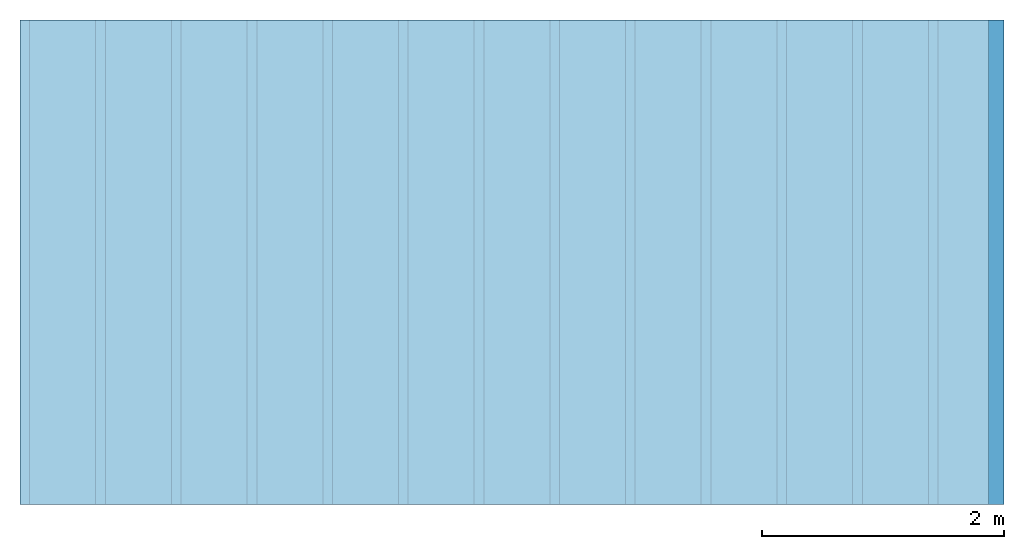
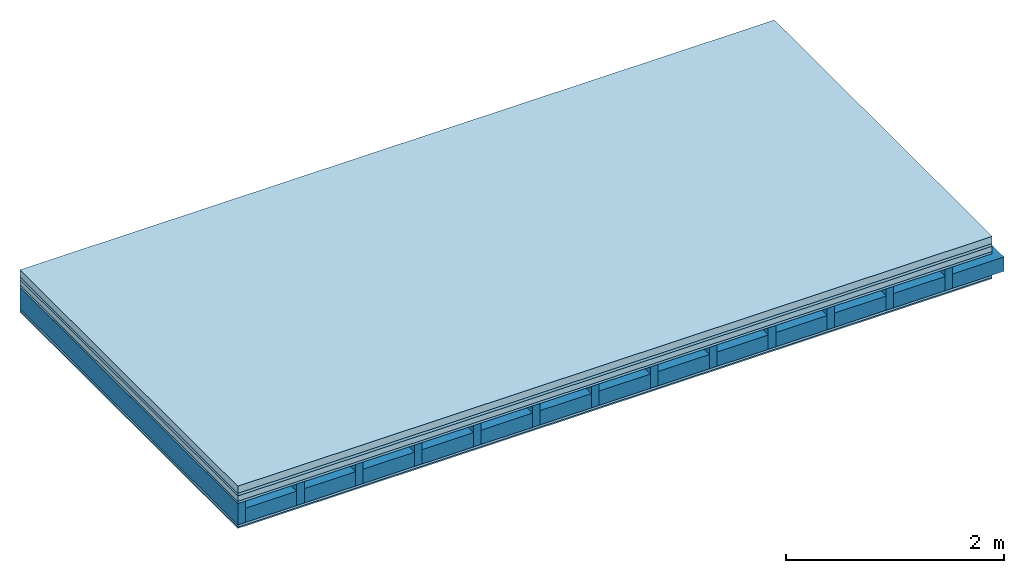
# One storey: 6 plates, 2 members, 1 element without a shape of its own.
"""IFC4 building model written with IfcOpenShell, lengths in metres."""

from ifc_helpers import new_model, si_unit, derived_unit, direction, frame, frame_2d, origin, origin_with_axes, place, context, project, spatial, rectangle, extrude, material, layer, layer_set, type_object, element, aggregate, save


model = new_model("IFC4")

# Units and contexts
plan_context = context("Plan", 3, precision=1e-05, world=origin(), true_north=direction((0.0, 1.0)))
model_context = context("Model", 3, precision=1e-05, world=origin(), true_north=direction((0.0, 1.0)))
ifc_project = project(units=[si_unit("LENGTHUNIT", "METRE"), derived_unit("SOUNDPRESSUREUNIT", [(si_unit("PRESSUREUNIT", "PASCAL", prefix="MICRO"), 0)]), si_unit("ENERGYUNIT", "JOULE", prefix="MEGA"), si_unit("MASSUNIT", "GRAM", prefix="KILO"), derived_unit("THERMALTRANSMITTANCEUNIT", [(si_unit("POWERUNIT", "WATT"), 1), (si_unit("AREAUNIT", "SQUARE_METRE"), -1), (si_unit("THERMODYNAMICTEMPERATUREUNIT", "KELVIN"), -1)]), derived_unit("AREADENSITYUNIT", [(si_unit("MASSUNIT", "GRAM", prefix="KILO"), 1), (si_unit("AREAUNIT", "SQUARE_METRE"), -1)]), derived_unit("USERDEFINED", [(si_unit("ENERGYUNIT", "JOULE", prefix="MEGA"), 1), (si_unit("AREAUNIT", "SQUARE_METRE"), -1)])], contexts=[plan_context, model_context])

# Site, building, storey
site = spatial("IfcSite", under=ifc_project)
building_placement = place(None, origin())
building = spatial("IfcBuilding", under=site, at=building_placement)
storey_placement = place(building_placement, origin())
storey = spatial("IfcBuildingStorey", under=building, at=storey_placement)

# Slab, members, plates
ifc_material_1 = material(Name="Cement screed", Category="04.006")
ifc_layer_1 = layer(ifc_material_1, 0.08, Name="On-material")
ifc_material_2 = material()
ifc_layer_2 = layer(ifc_material_2, 0.03, Name="Impact sound insulation")
ifc_material_3 = material(Name="Cement panels, glued on sub-floor", Category="02.007")
ifc_layer_3 = layer(ifc_material_3, 0.06, Name="on Supporting structure")
ifc_material_4 = material(Category="07.001")
ifc_layer_4 = layer(ifc_material_4, 0.025, Name="Sub-floor")
ifc_material_5 = material(Name="Rigid, of the art")
ifc_layer_5 = layer(ifc_material_5, 0.0, Name="Bond")
ifc_layer_6 = layer(None, 0.24, Name="Supporting structure")
ifc_layer_7 = layer(ifc_material_5, 0.0, Name="Bond")
ifc_layer_8 = layer(ifc_material_4, 0.025, Name="Lower layer 1")
ifc_material_6 = material(Category="03.007")
ifc_layer_9 = layer(ifc_material_6, 0.015, Name="Lower 2nd layer")
ifc_layer_set = layer_set([ifc_layer_1, ifc_layer_2, ifc_layer_3, ifc_layer_4, ifc_layer_5, ifc_layer_6, ifc_layer_7, ifc_layer_8, ifc_layer_9])
slab_type = type_object("IfcSlabType", Name="A0432", PredefinedType="NOTDEFINED", material=ifc_layer_set)
slab_placement = place(None, frame((0.0, 0.0, 0.0), z_axis=(0.0, 0.0, -1.0), x_axis=(1.0, 0.0, 0.0)))
slab = element("IfcSlab", 1, at=slab_placement, inside=storey, type_object=slab_type, material=ifc_layer_set, Name="Slab #1")
ifc_material_7 = material()
member_1_placement = place(slab_placement, origin())
member_1 = element("IfcMember", 2, at=member_1_placement, material=ifc_material_7, Name="Supporting structure", context=plan_context, shape_type="SweptSolid", body=[
    extrude(rectangle(XDim=0.08, YDim=0.24, at=frame_2d((0.04, 0.12), x_axis=(1.0, 0.0))), frame((0.0, 4.0, 0.195), z_axis=(0.0, -1.0, 0.0), x_axis=(1.0, 0.0, 0.0)), (0.0, 0.0, 1.0), 4.0),
    extrude(rectangle(XDim=0.08, YDim=0.24, at=frame_2d((0.04, 0.12), x_axis=(1.0, 0.0))), frame((0.625, 4.0, 0.195), z_axis=(0.0, -1.0, 0.0), x_axis=(1.0, 0.0, 0.0)), (0.0, 0.0, 1.0), 4.0),
    extrude(rectangle(XDim=0.08, YDim=0.24, at=frame_2d((0.04, 0.12), x_axis=(1.0, 0.0))), frame((1.25, 4.0, 0.195), z_axis=(0.0, -1.0, 0.0), x_axis=(1.0, 0.0, 0.0)), (0.0, 0.0, 1.0), 4.0),
    extrude(rectangle(XDim=0.08, YDim=0.24, at=frame_2d((0.04, 0.12), x_axis=(1.0, 0.0))), frame((1.875, 4.0, 0.195), z_axis=(0.0, -1.0, 0.0), x_axis=(1.0, 0.0, 0.0)), (0.0, 0.0, 1.0), 4.0),
    extrude(rectangle(XDim=0.08, YDim=0.24, at=frame_2d((0.04, 0.12), x_axis=(1.0, 0.0))), frame((2.5, 4.0, 0.195), z_axis=(0.0, -1.0, 0.0), x_axis=(1.0, 0.0, 0.0)), (0.0, 0.0, 1.0), 4.0),
    extrude(rectangle(XDim=0.08, YDim=0.24, at=frame_2d((0.04, 0.12), x_axis=(1.0, 0.0))), frame((3.125, 4.0, 0.195), z_axis=(0.0, -1.0, 0.0), x_axis=(1.0, 0.0, 0.0)), (0.0, 0.0, 1.0), 4.0),
    extrude(rectangle(XDim=0.08, YDim=0.24, at=frame_2d((0.04, 0.12), x_axis=(1.0, 0.0))), frame((3.75, 4.0, 0.195), z_axis=(0.0, -1.0, 0.0), x_axis=(1.0, 0.0, 0.0)), (0.0, 0.0, 1.0), 4.0),
    extrude(rectangle(XDim=0.08, YDim=0.24, at=frame_2d((0.04, 0.12), x_axis=(1.0, 0.0))), frame((4.375, 4.0, 0.195), z_axis=(0.0, -1.0, 0.0), x_axis=(1.0, 0.0, 0.0)), (0.0, 0.0, 1.0), 4.0),
    extrude(rectangle(XDim=0.08, YDim=0.24, at=frame_2d((0.04, 0.12), x_axis=(1.0, 0.0))), frame((5.0, 4.0, 0.195), z_axis=(0.0, -1.0, 0.0), x_axis=(1.0, 0.0, 0.0)), (0.0, 0.0, 1.0), 4.0),
    extrude(rectangle(XDim=0.08, YDim=0.24, at=frame_2d((0.04, 0.12), x_axis=(1.0, 0.0))), frame((5.625, 4.0, 0.195), z_axis=(0.0, -1.0, 0.0), x_axis=(1.0, 0.0, 0.0)), (0.0, 0.0, 1.0), 4.0),
    extrude(rectangle(XDim=0.08, YDim=0.24, at=frame_2d((0.04, 0.12), x_axis=(1.0, 0.0))), frame((6.25, 4.0, 0.195), z_axis=(0.0, -1.0, 0.0), x_axis=(1.0, 0.0, 0.0)), (0.0, 0.0, 1.0), 4.0),
    extrude(rectangle(XDim=0.08, YDim=0.24, at=frame_2d((0.04, 0.12), x_axis=(1.0, 0.0))), frame((6.875, 4.0, 0.195), z_axis=(0.0, -1.0, 0.0), x_axis=(1.0, 0.0, 0.0)), (0.0, 0.0, 1.0), 4.0),
    extrude(rectangle(XDim=0.08, YDim=0.24, at=frame_2d((0.04, 0.12), x_axis=(1.0, 0.0))), frame((7.5, 4.0, 0.195), z_axis=(0.0, -1.0, 0.0), x_axis=(1.0, 0.0, 0.0)), (0.0, 0.0, 1.0), 4.0),
])
ifc_material_8 = material()
member_2_placement = place(slab_placement, origin())
member_2 = element("IfcMember", 3, at=member_2_placement, material=ifc_material_8, Name="Cavity", context=plan_context, shape_type="SweptSolid", body=[
    extrude(rectangle(XDim=0.545, YDim=0.16, at=frame_2d((0.2725, 0.08), x_axis=(1.0, 0.0))), frame((0.08, 4.0, 0.275), z_axis=(0.0, -1.0, 0.0), x_axis=(1.0, 0.0, 0.0)), (0.0, 0.0, 1.0), 4.0),
    extrude(rectangle(XDim=0.545, YDim=0.16, at=frame_2d((0.2725, 0.08), x_axis=(1.0, 0.0))), frame((0.705, 4.0, 0.275), z_axis=(0.0, -1.0, 0.0), x_axis=(1.0, 0.0, 0.0)), (0.0, 0.0, 1.0), 4.0),
    extrude(rectangle(XDim=0.545, YDim=0.16, at=frame_2d((0.2725, 0.08), x_axis=(1.0, 0.0))), frame((1.33, 4.0, 0.275), z_axis=(0.0, -1.0, 0.0), x_axis=(1.0, 0.0, 0.0)), (0.0, 0.0, 1.0), 4.0),
    extrude(rectangle(XDim=0.545, YDim=0.16, at=frame_2d((0.2725, 0.08), x_axis=(1.0, 0.0))), frame((1.955, 4.0, 0.275), z_axis=(0.0, -1.0, 0.0), x_axis=(1.0, 0.0, 0.0)), (0.0, 0.0, 1.0), 4.0),
    extrude(rectangle(XDim=0.545, YDim=0.16, at=frame_2d((0.2725, 0.08), x_axis=(1.0, 0.0))), frame((2.58, 4.0, 0.275), z_axis=(0.0, -1.0, 0.0), x_axis=(1.0, 0.0, 0.0)), (0.0, 0.0, 1.0), 4.0),
    extrude(rectangle(XDim=0.545, YDim=0.16, at=frame_2d((0.2725, 0.08), x_axis=(1.0, 0.0))), frame((3.205, 4.0, 0.275), z_axis=(0.0, -1.0, 0.0), x_axis=(1.0, 0.0, 0.0)), (0.0, 0.0, 1.0), 4.0),
    extrude(rectangle(XDim=0.545, YDim=0.16, at=frame_2d((0.2725, 0.08), x_axis=(1.0, 0.0))), frame((3.83, 4.0, 0.275), z_axis=(0.0, -1.0, 0.0), x_axis=(1.0, 0.0, 0.0)), (0.0, 0.0, 1.0), 4.0),
    extrude(rectangle(XDim=0.545, YDim=0.16, at=frame_2d((0.2725, 0.08), x_axis=(1.0, 0.0))), frame((4.455, 4.0, 0.275), z_axis=(0.0, -1.0, 0.0), x_axis=(1.0, 0.0, 0.0)), (0.0, 0.0, 1.0), 4.0),
    extrude(rectangle(XDim=0.545, YDim=0.16, at=frame_2d((0.2725, 0.08), x_axis=(1.0, 0.0))), frame((5.08, 4.0, 0.275), z_axis=(0.0, -1.0, 0.0), x_axis=(1.0, 0.0, 0.0)), (0.0, 0.0, 1.0), 4.0),
    extrude(rectangle(XDim=0.545, YDim=0.16, at=frame_2d((0.2725, 0.08), x_axis=(1.0, 0.0))), frame((5.705, 4.0, 0.275), z_axis=(0.0, -1.0, 0.0), x_axis=(1.0, 0.0, 0.0)), (0.0, 0.0, 1.0), 4.0),
    extrude(rectangle(XDim=0.545, YDim=0.16, at=frame_2d((0.2725, 0.08), x_axis=(1.0, 0.0))), frame((6.33, 4.0, 0.275), z_axis=(0.0, -1.0, 0.0), x_axis=(1.0, 0.0, 0.0)), (0.0, 0.0, 1.0), 4.0),
    extrude(rectangle(XDim=0.545, YDim=0.16, at=frame_2d((0.2725, 0.08), x_axis=(1.0, 0.0))), frame((6.955, 4.0, 0.275), z_axis=(0.0, -1.0, 0.0), x_axis=(1.0, 0.0, 0.0)), (0.0, 0.0, 1.0), 4.0),
    extrude(rectangle(XDim=0.545, YDim=0.16, at=frame_2d((0.2725, 0.08), x_axis=(1.0, 0.0))), frame((7.58, 4.0, 0.275), z_axis=(0.0, -1.0, 0.0), x_axis=(1.0, 0.0, 0.0)), (0.0, 0.0, 1.0), 4.0),
])
plate_1_placement = place(slab_placement, origin())
plate_1 = element("IfcPlate", 4, at=plate_1_placement, material=ifc_material_1, Name="On-material", context=plan_context, shape_type="SweptSolid", body=[
    extrude(rectangle(XDim=8.0, YDim=4.0, at=frame_2d((4.0, 2.0), x_axis=(1.0, 0.0))), origin_with_axes(), (0.0, 0.0, 1.0), 0.08),
])
plate_2_placement = place(slab_placement, origin())
plate_2 = element("IfcPlate", 5, at=plate_2_placement, material=ifc_material_2, Name="Impact sound insulation", context=plan_context, shape_type="SweptSolid", body=[
    extrude(rectangle(XDim=8.0, YDim=4.0, at=frame_2d((4.0, 2.0), x_axis=(1.0, 0.0))), frame((0.0, 0.0, 0.08), z_axis=(0.0, 0.0, 1.0), x_axis=(1.0, 0.0, 0.0)), (0.0, 0.0, 1.0), 0.03),
])
plate_3_placement = place(slab_placement, origin())
plate_3 = element("IfcPlate", 6, at=plate_3_placement, material=ifc_material_3, Name="on Supporting structure", context=plan_context, shape_type="SweptSolid", body=[
    extrude(rectangle(XDim=8.0, YDim=4.0, at=frame_2d((4.0, 2.0), x_axis=(1.0, 0.0))), frame((0.0, 0.0, 0.11), z_axis=(0.0, 0.0, 1.0), x_axis=(1.0, 0.0, 0.0)), (0.0, 0.0, 1.0), 0.06),
])
plate_4_placement = place(slab_placement, origin())
plate_4 = element("IfcPlate", 7, at=plate_4_placement, material=ifc_material_4, Name="Sub-floor", context=plan_context, shape_type="SweptSolid", body=[
    extrude(rectangle(XDim=8.0, YDim=4.0, at=frame_2d((4.0, 2.0), x_axis=(1.0, 0.0))), frame((0.0, 0.0, 0.17), z_axis=(0.0, 0.0, 1.0), x_axis=(1.0, 0.0, 0.0)), (0.0, 0.0, 1.0), 0.025),
])
plate_5_placement = place(slab_placement, origin())
plate_5 = element("IfcPlate", 8, at=plate_5_placement, material=ifc_material_4, Name="Lower layer 1", context=plan_context, shape_type="SweptSolid", body=[
    extrude(rectangle(XDim=8.0, YDim=4.0, at=frame_2d((4.0, 2.0), x_axis=(1.0, 0.0))), frame((0.0, 0.0, 0.435), z_axis=(0.0, 0.0, 1.0), x_axis=(1.0, 0.0, 0.0)), (0.0, 0.0, 1.0), 0.025),
])
plate_6_placement = place(slab_placement, origin())
plate_6 = element("IfcPlate", 9, at=plate_6_placement, material=ifc_material_6, Name="Lower 2nd layer", context=plan_context, shape_type="SweptSolid", body=[
    extrude(rectangle(XDim=8.0, YDim=4.0, at=frame_2d((4.0, 2.0), x_axis=(1.0, 0.0))), frame((0.0, 0.0, 0.46), z_axis=(0.0, 0.0, 1.0), x_axis=(1.0, 0.0, 0.0)), (0.0, 0.0, 1.0), 0.015),
])
aggregate(slab, [plate_1, plate_2, plate_3, plate_4, member_1, member_2, plate_5, plate_6])

save(model, "model.ifc")
